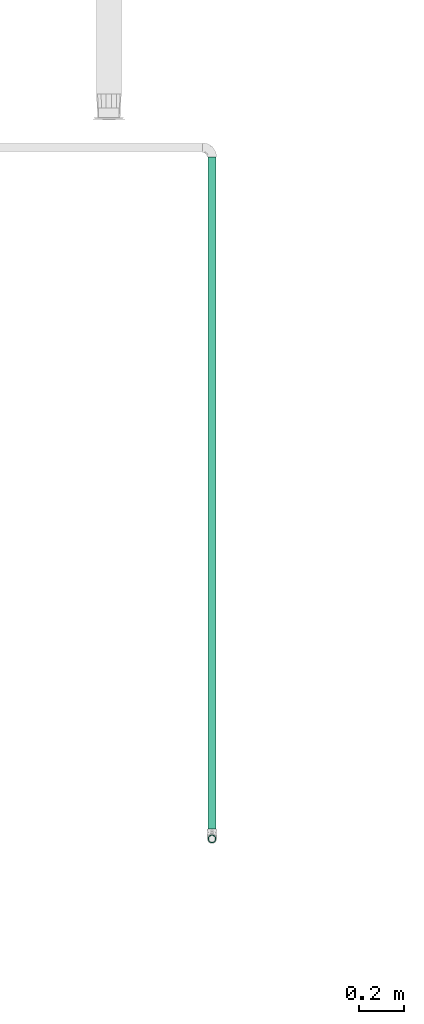
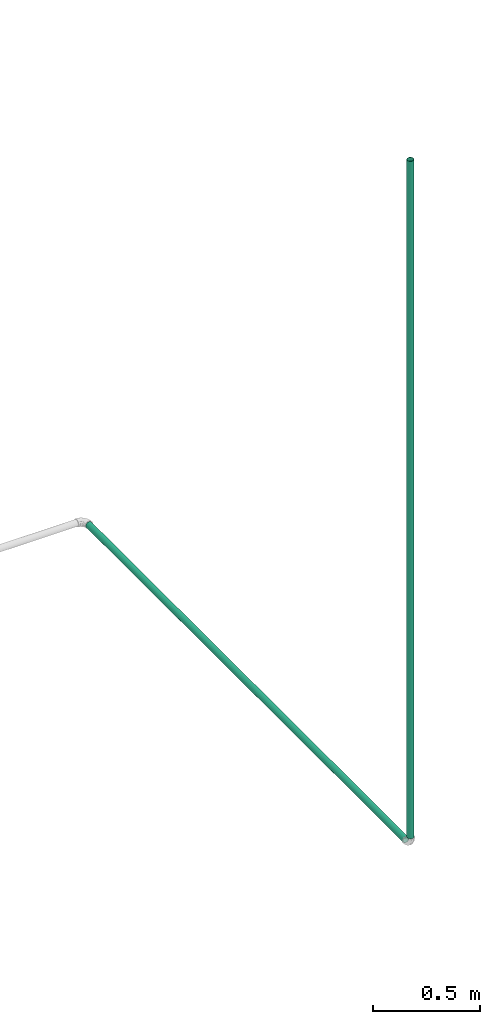
# One storey, part 21 of 123: 2 flow segments.
"""IFC2X3 building model written with IfcOpenShell, lengths in millimetres."""

from ifc_helpers import new_model, entity, si_unit, converted_unit, derived_unit, direction, frame, origin_with_axes, origin_2d_with_axis, place, context, subcontext, project, spatial, hollow_circle, extrude, source, transform, mapped, material, layer, layer_set, layer_usage, type_object, element, save


model = new_model("IFC2X3")

# Units and contexts
model_context = context("Model", 3, precision=1e-05, world=origin_with_axes(), true_north=direction((0.0, 1.0)))
body_context = subcontext(model_context, "Body", "Model", "MODEL_VIEW")
ifc_project = project(units=[si_unit("AREAUNIT", "SQUARE_METRE"), si_unit("VOLUMEUNIT", "CUBIC_METRE", prefix="DECI"), si_unit("TIMEUNIT", "SECOND"), si_unit("THERMODYNAMICTEMPERATUREUNIT", "DEGREE_CELSIUS"), si_unit("PRESSUREUNIT", "PASCAL"), si_unit("MASSUNIT", "GRAM", prefix="KILO"), si_unit("LENGTHUNIT", "METRE", prefix="MILLI"), si_unit("POWERUNIT", "WATT"), si_unit("ELECTRICCURRENTUNIT", "AMPERE"), si_unit("ELECTRICVOLTAGEUNIT", "VOLT"), derived_unit("VOLUMETRICFLOWRATEUNIT", [(si_unit("VOLUMEUNIT", "CUBIC_METRE", prefix="DECI"), 1), (si_unit("TIMEUNIT", "SECOND"), -1)]), derived_unit("LINEARVELOCITYUNIT", [(si_unit("LENGTHUNIT", "METRE"), 1), (si_unit("TIMEUNIT", "SECOND"), -1)]), derived_unit("MASSDENSITYUNIT", [(si_unit("MASSUNIT", "GRAM", prefix="KILO"), 1), (si_unit("VOLUMEUNIT", "CUBIC_METRE"), -1)]), converted_unit("PLANEANGLEUNIT", "DEGREE", entity("IfcRatioMeasure", 0.01745), si_unit("PLANEANGLEUNIT", "RADIAN"), dimensions=[0, 0, 0, 0, 0, 0, 0])], contexts=[model_context])

# Site, building, storey
site_placement = place(None, origin_with_axes())
site = spatial("IfcSite", under=ifc_project, at=site_placement, CompositionType="ELEMENT")
building_placement = place(site_placement, origin_with_axes())
building = spatial("IfcBuilding", under=site, at=building_placement, Name="mc-building", CompositionType="ELEMENT")
storey_placement = place(building_placement, origin_with_axes())
storey = spatial("IfcBuildingStorey", under=building, at=storey_placement, Name="1. Korrus", CompositionType="ELEMENT", Elevation=0.0)

# Flow segments
ifc_material = material(Name="Steel")
ifc_layer = layer(ifc_material, 0.0)
ifc_layer_set = layer_set([ifc_layer], Name="Steel")
ifc_layer_usage = layer_usage(ifc_layer_set, "AXIS1", "POSITIVE", 0.0)
pipe_segment_type = type_object("IfcPipeSegmentType", PredefinedType="RIGIDSEGMENT")
shared_shape_1 = source(origin_with_axes(), body_context, "Body", "SweptSolid", [
    extrude(hollow_circle(Radius=17.5, WallThickness=2.0, at=origin_2d_with_axis()), frame((0.0, 0.0, 0.0), z_axis=(1.0, 0.0, 0.0), x_axis=(0.0, 1.0, 0.0)), (0.0, 0.0, 1.0), 2956.6),
])
flow_segment_1_placement = place(storey_placement, frame((36845.43736, 12765.51734, 2520.89768), z_axis=(0.0, 0.0, 1.0), x_axis=(0.0, -1.0, 0.0)))
element("IfcFlowSegment", 1, at=flow_segment_1_placement, inside=storey, type_object=pipe_segment_type, material=ifc_layer_usage, context=body_context, shape_type="MappedRepresentation", body=[
    mapped(shared_shape_1, transform((0.0, 0.0, 0.0), scale=1.0)),
])
shared_shape_2 = source(origin_with_axes(), body_context, "Body", "SweptSolid", [
    extrude(hollow_circle(Radius=17.5, WallThickness=2.0, at=origin_2d_with_axis()), frame((0.0, 0.0, 0.0), z_axis=(1.0, 0.0, 0.0), x_axis=(0.0, 1.0, 0.0)), (0.0, 0.0, 1.0), 3857.6),
])
flow_segment_2_placement = place(storey_placement, frame((36845.43736, 9766.46738, 2563.29768), z_axis=(-1.0, 0.0, 0.0), x_axis=(0.0, 0.0, 1.0)))
element("IfcFlowSegment", 2, at=flow_segment_2_placement, inside=storey, type_object=pipe_segment_type, material=ifc_layer_usage, context=body_context, shape_type="MappedRepresentation", body=[
    mapped(shared_shape_2, transform((0.0, 0.0, 0.0), scale=1.0)),
])

save(model, "model.ifc")
